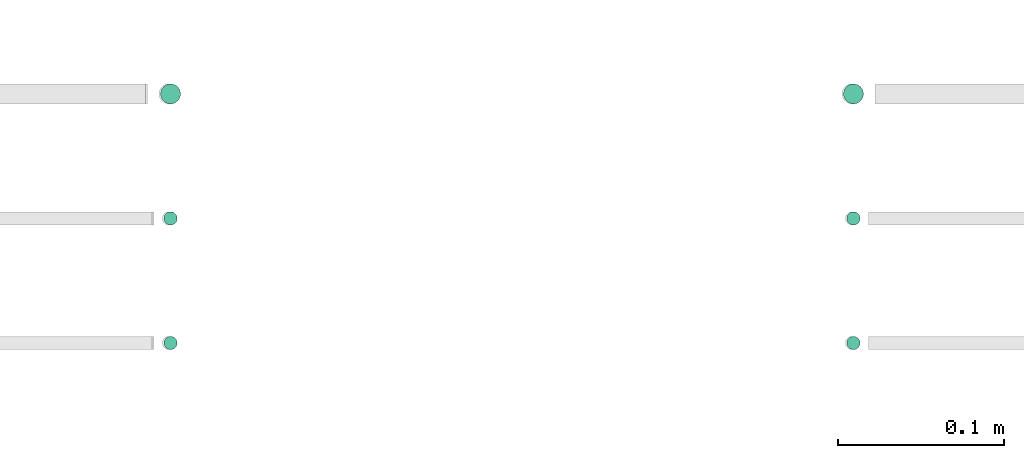
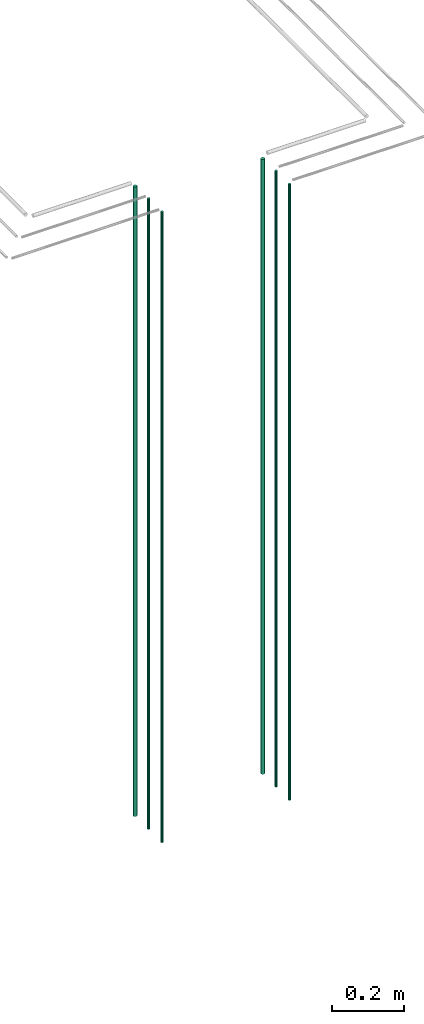
# One storey, part 39 of 331: 6 flow segments.
"""IFC2X3 building model written with IfcOpenShell, lengths in millimetres."""

from ifc_helpers import new_model, entity, si_unit, converted_unit, derived_unit, direction, frame, origin, origin_2d_with_axis, place, context, subcontext, project, spatial, circle, extrude, type_object, element, save


model = new_model("IFC2X3")

# Units and contexts
model_context = context("Model", 3, precision=0.01, world=origin(), true_north=direction((6.12303176911189e-17, 1.0)))
body_context = subcontext(model_context, "Body", "Model", "MODEL_VIEW")
ifc_project = project(units=[si_unit("LENGTHUNIT", "METRE", prefix="MILLI"), si_unit("AREAUNIT", "SQUARE_METRE"), si_unit("VOLUMEUNIT", "CUBIC_METRE"), converted_unit("PLANEANGLEUNIT", "DEGREE", entity("IfcRatioMeasure", 0.0174532925199433), si_unit("PLANEANGLEUNIT", "RADIAN"), dimensions=[0, 0, 0, 0, 0, 0, 0]), si_unit("MASSUNIT", "GRAM", prefix="KILO"), derived_unit("MASSDENSITYUNIT", [(si_unit("MASSUNIT", "GRAM", prefix="KILO"), 1), (si_unit("LENGTHUNIT", "METRE"), -3)]), derived_unit("MOMENTOFINERTIAUNIT", [(si_unit("LENGTHUNIT", "METRE"), 4)]), si_unit("TIMEUNIT", "SECOND"), si_unit("FREQUENCYUNIT", "HERTZ"), si_unit("THERMODYNAMICTEMPERATUREUNIT", "DEGREE_CELSIUS"), derived_unit("THERMALTRANSMITTANCEUNIT", [(si_unit("MASSUNIT", "GRAM", prefix="KILO"), 1), (si_unit("THERMODYNAMICTEMPERATUREUNIT", "KELVIN"), -1), (si_unit("TIMEUNIT", "SECOND"), -3)]), derived_unit("VOLUMETRICFLOWRATEUNIT", [(si_unit("LENGTHUNIT", "METRE"), 3), (si_unit("TIMEUNIT", "SECOND"), -1)]), derived_unit("MASSFLOWRATEUNIT", [(si_unit("MASSUNIT", "GRAM", prefix="KILO"), 1), (si_unit("TIMEUNIT", "SECOND"), -1)]), derived_unit("ROTATIONALFREQUENCYUNIT", [(si_unit("TIMEUNIT", "SECOND"), -1)]), si_unit("ELECTRICCURRENTUNIT", "AMPERE"), si_unit("ELECTRICVOLTAGEUNIT", "VOLT"), si_unit("POWERUNIT", "WATT"), si_unit("FORCEUNIT", "NEWTON", prefix="KILO"), si_unit("ILLUMINANCEUNIT", "LUX"), si_unit("LUMINOUSFLUXUNIT", "LUMEN"), si_unit("LUMINOUSINTENSITYUNIT", "CANDELA"), derived_unit("USERDEFINED", [(si_unit("MASSUNIT", "GRAM", prefix="KILO"), -1), (si_unit("LENGTHUNIT", "METRE"), -2), (si_unit("TIMEUNIT", "SECOND"), 3), (si_unit("LUMINOUSFLUXUNIT", "LUMEN"), 1)]), derived_unit("LINEARVELOCITYUNIT", [(si_unit("LENGTHUNIT", "METRE"), 1), (si_unit("TIMEUNIT", "SECOND"), -1)]), si_unit("PRESSUREUNIT", "PASCAL"), derived_unit("USERDEFINED", [(si_unit("LENGTHUNIT", "METRE"), -2), (si_unit("MASSUNIT", "GRAM", prefix="KILO"), 1), (si_unit("TIMEUNIT", "SECOND"), -2)]), derived_unit("LINEARFORCEUNIT", [(si_unit("MASSUNIT", "GRAM", prefix="KILO"), 1), (si_unit("LENGTHUNIT", "METRE"), 1), (si_unit("TIMEUNIT", "SECOND"), -2), (si_unit("LENGTHUNIT", "METRE"), -1)]), derived_unit("PLANARFORCEUNIT", [(si_unit("MASSUNIT", "GRAM", prefix="KILO"), 1), (si_unit("LENGTHUNIT", "METRE"), 1), (si_unit("TIMEUNIT", "SECOND"), -2), (si_unit("LENGTHUNIT", "METRE"), -2)])], contexts=[model_context])

# Site, building, storey
site_placement = place(None, frame((0.0, -0.00077364408347762, 0.0)))
site = spatial("IfcSite", under=ifc_project, at=site_placement, CompositionType="ELEMENT")
building_placement = place(site_placement, origin())
building = spatial("IfcBuilding", under=site, at=building_placement, CompositionType="ELEMENT")
storey_placement = place(building_placement, origin())
storey = spatial("IfcBuildingStorey", under=building, at=storey_placement, CompositionType="ELEMENT", Elevation=0.0)

# Flow segments
pipe_segment_type = type_object("IfcPipeSegmentType", PredefinedType="NOTDEFINED")
flow_segment_1_placement = place(storey_placement, frame((44369.1288658284, 1343.8934948434, 12990.0)))
element("IfcFlowSegment", 1, at=flow_segment_1_placement, inside=storey, type_object=pipe_segment_type, context=body_context, shape_type="SweptSolid", body=[
    extrude(circle(Radius=6.0, at=origin_2d_with_axis()), frame((7.59527223591454, 7.59527223591589, 0.0)), (0.0, 0.0, 1.0), 2096.0),
])
flow_segment_2_placement = place(storey_placement, frame((44371.1288658284, 1270.89349484378, 12990.0)))
element("IfcFlowSegment", 2, at=flow_segment_2_placement, inside=storey, type_object=pipe_segment_type, context=body_context, shape_type="SweptSolid", body=[
    extrude(circle(Radius=4.0, at=origin_2d_with_axis()), frame((5.59527223591499, 5.5952722359158, 0.0)), (0.0, 0.0, 1.0), 2100.0),
])
flow_segment_3_placement = place(storey_placement, frame((44371.1288658284, 1195.89349484352, 12990.0)))
element("IfcFlowSegment", 3, at=flow_segment_3_placement, inside=storey, type_object=pipe_segment_type, context=body_context, shape_type="SweptSolid", body=[
    extrude(circle(Radius=4.0, at=origin_2d_with_axis()), frame((5.59527223591499, 5.59527223591607, 0.0)), (0.0, 0.0, 1.0), 2100.0),
])
flow_segment_4_placement = place(storey_placement, frame((43957.8885868351, 1343.89349484345, 12990.0)))
element("IfcFlowSegment", 4, at=flow_segment_4_placement, inside=storey, type_object=pipe_segment_type, context=body_context, shape_type="SweptSolid", body=[
    extrude(circle(Radius=6.0, at=origin_2d_with_axis()), frame((7.59527223591454, 7.59527223591589, 0.0)), (0.0, 0.0, 1.0), 2146.0),
])
flow_segment_5_placement = place(storey_placement, frame((43959.8885868351, 1270.89349484379, 12990.0)))
element("IfcFlowSegment", 5, at=flow_segment_5_placement, inside=storey, type_object=pipe_segment_type, context=body_context, shape_type="SweptSolid", body=[
    extrude(circle(Radius=4.0, at=origin_2d_with_axis()), frame((5.59527223591499, 5.5952722359158, 0.0)), (0.0, 0.0, 1.0), 2150.00000000001),
])
flow_segment_6_placement = place(storey_placement, frame((43959.8885868351, 1195.89349484356, 12990.0)))
element("IfcFlowSegment", 6, at=flow_segment_6_placement, inside=storey, type_object=pipe_segment_type, context=body_context, shape_type="SweptSolid", body=[
    extrude(circle(Radius=4.0, at=origin_2d_with_axis()), frame((5.59527223591499, 5.59527223591607, 0.0)), (0.0, 0.0, 1.0), 2150.00000000001),
])

save(model, "model.ifc")
